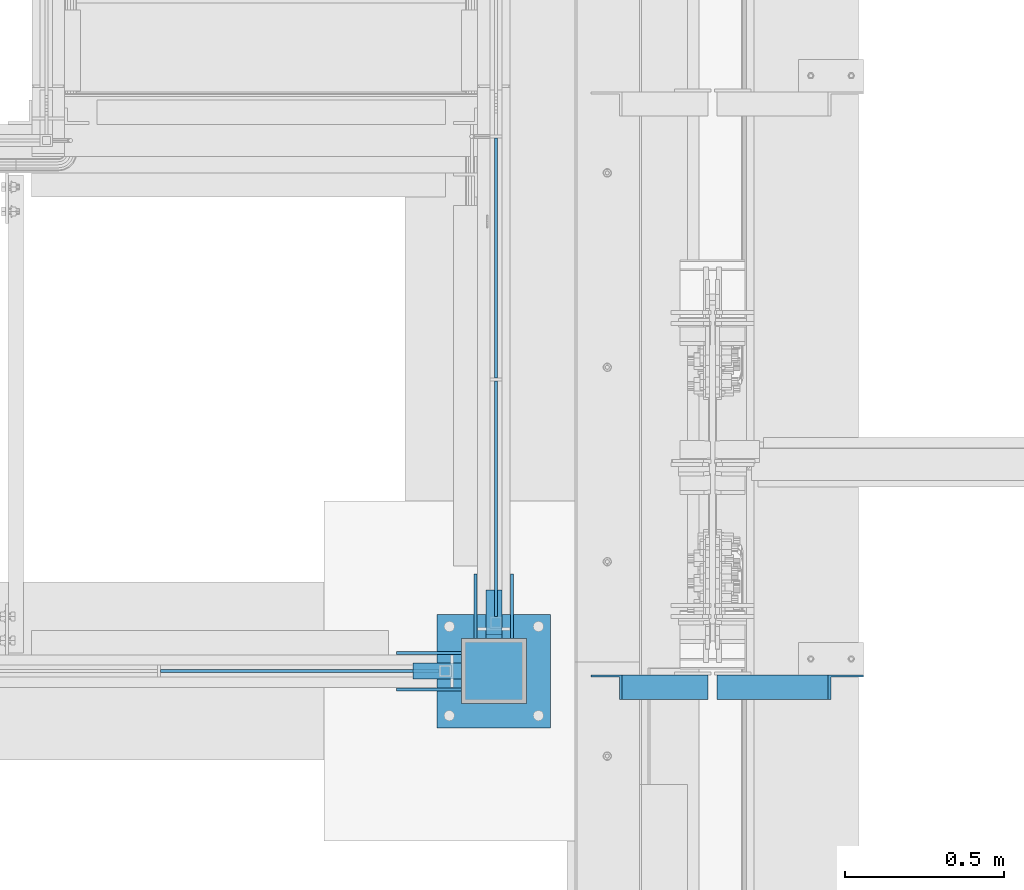
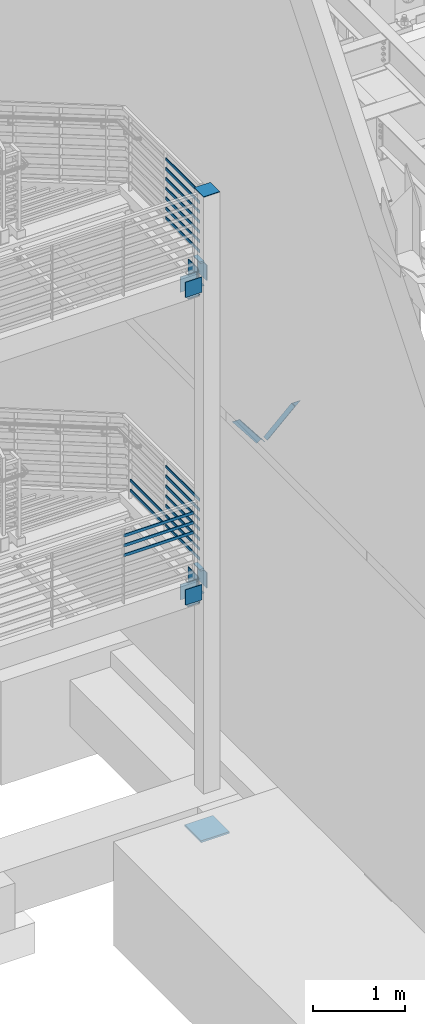
# One storey, part 833 of 1179: 35 beams, 2 members, 8 elements without a shape of their own.
"""IFC2X3 building model written with IfcOpenShell, lengths in millimetres."""

from ifc_helpers import new_model, si_unit, frame, origin_with_axes, place, context, subcontext, project, spatial, faceted_brep, material, type_object, element, aggregate, save


model = new_model("IFC2X3")

# Units and contexts
model_context = context("Model", 3, precision=1e-05, world=origin_with_axes())
body_context = subcontext(model_context, "Body", "Model", "MODEL_VIEW")
ifc_project = project(units=[si_unit("LENGTHUNIT", "METRE", prefix="MILLI"), si_unit("AREAUNIT", "SQUARE_METRE"), si_unit("VOLUMEUNIT", "CUBIC_METRE"), si_unit("MASSUNIT", "GRAM", prefix="KILO"), si_unit("TIMEUNIT", "SECOND"), si_unit("PLANEANGLEUNIT", "RADIAN"), si_unit("SOLIDANGLEUNIT", "STERADIAN"), si_unit("THERMODYNAMICTEMPERATUREUNIT", "DEGREE_CELSIUS"), si_unit("LUMINOUSINTENSITYUNIT", "LUMEN")], contexts=[model_context])

# Site, building, storey
site_placement = place(None, origin_with_axes())
site = spatial("IfcSite", under=ifc_project, at=site_placement, CompositionType="ELEMENT")
building_placement = place(site_placement, origin_with_axes())
building = spatial("IfcBuilding", under=site, at=building_placement, Name="Undefined", CompositionType="ELEMENT")
storey_placement = place(building_placement, origin_with_axes())
storey = spatial("IfcBuildingStorey", under=building, at=storey_placement, Name="Undefined", CompositionType="ELEMENT", Elevation=0.0)

# Assembly, beam
assembly_1_placement = place(storey_placement, origin_with_axes())
assembly_1 = element("IfcElementAssembly", 1, at=assembly_1_placement, inside=storey, Name="COLUMN", AssemblyPlace="NOTDEFINED", PredefinedType="RIGID_FRAME")
ifc_material_1 = material(Name="STEEL/A572-GR.50")
beam_type_1 = type_object("IfcBeamType", PredefinedType="NOTDEFINED")
beam_1_placement = place(assembly_1_placement, frame((-254.000000000004, 30327.6, 1857.375), z_axis=(1.0, 0.0, 0.0), x_axis=(0.0, -1.0, 0.0)))
beam_1 = element("IfcBeam", 2, at=beam_1_placement, type_object=beam_type_1, material=ifc_material_1, Name="PLATE", context=body_context, shape_type="Brep", body=[
    faceted_brep([(152.400000000001, -6.35000000000036, 25.4), (152.400000000001, -6.35000000000036, -25.4), (139.700000000004, 6.35000000000036, -25.4), (139.700000000004, 6.35000000000036, 25.4), (0.0, -6.35000000000036, -25.4000000000015), (0.0, -6.35000000000036, 25.4000000000015), (0.0, 6.35000000000036, 25.4000000000015), (0.0, 6.35000000000036, -25.4000000000015)], [[[0, 1, 2, 3]], [[4, 5, 6, 7]], [[6, 5, 0, 3]], [[7, 6, 3, 2]], [[4, 7, 2, 1]], [[5, 4, 1, 0]]]),
])

assembly_2_placement = place(storey_placement, origin_with_axes())
assembly_2 = element("IfcElementAssembly", 3, at=assembly_2_placement, inside=storey, Name="PLATE", AssemblyPlace="NOTDEFINED", PredefinedType="RIGID_FRAME")
beam_2_placement = place(assembly_2_placement, frame((-254.000000000004, 30327.6, 2174.875), z_axis=(1.0, 0.0, 0.0), x_axis=(0.0, -1.0, 0.0)))
beam_2 = element("IfcBeam", 4, at=beam_2_placement, type_object=beam_type_1, material=ifc_material_1, Name="PLATE", context=body_context, shape_type="Brep", body=[
    faceted_brep([(152.399999999998, 6.35000000000036, 25.4000000000015), (139.699999999998, -6.35000000000036, 25.4000000000015), (139.699999999998, -6.35000000000036, -25.4000000000015), (152.399999999998, 6.35000000000036, -25.4000000000015), (0.0, -6.35000000000036, -25.4000000000015), (0.0, -6.35000000000036, 25.4000000000015), (0.0, 6.35000000000036, 25.4000000000015), (0.0, 6.35000000000036, -25.4000000000015)], [[[0, 1, 2, 3]], [[4, 5, 6, 7]], [[7, 6, 0, 3]], [[4, 7, 3, 2]], [[5, 4, 2, 1]], [[6, 5, 1, 0]]]),
])
aggregate(assembly_2, [beam_2])

# Beam
beam_3_placement = place(assembly_1_placement, frame((-254.000000000004, 30327.6, 5930.9), z_axis=(1.0, 0.0, 0.0), x_axis=(0.0, -1.0, 0.0)))
beam_3 = element("IfcBeam", 5, at=beam_3_placement, type_object=beam_type_1, material=ifc_material_1, Name="PLATE", context=body_context, shape_type="Brep", body=[
    faceted_brep([(152.400000000001, -6.35000000000036, 25.4), (152.400000000001, -6.35000000000036, -25.4), (139.700000000004, 6.35000000000036, -25.4), (139.700000000004, 6.35000000000036, 25.4), (0.0, -6.35000000000036, -25.4000000000015), (0.0, -6.35000000000036, 25.4000000000015), (0.0, 6.35000000000036, 25.4000000000015), (0.0, 6.35000000000036, -25.4000000000015)], [[[0, 1, 2, 3]], [[4, 5, 6, 7]], [[6, 5, 0, 3]], [[7, 6, 3, 2]], [[4, 7, 2, 1]], [[5, 4, 1, 0]]]),
])

# Assembly, beam
assembly_3_placement = place(storey_placement, origin_with_axes())
assembly_3 = element("IfcElementAssembly", 6, at=assembly_3_placement, inside=storey, Name="PLATE", AssemblyPlace="NOTDEFINED", PredefinedType="RIGID_FRAME")
beam_4_placement = place(assembly_3_placement, frame((-254.000000000004, 30327.6, 6248.4), z_axis=(1.0, 0.0, 0.0), x_axis=(0.0, -1.0, 0.0)))
beam_4 = element("IfcBeam", 7, at=beam_4_placement, type_object=beam_type_1, material=ifc_material_1, Name="PLATE", context=body_context, shape_type="Brep", body=[
    faceted_brep([(152.399999999998, 6.35000000000036, 25.4000000000015), (139.699999999998, -6.35000000000036, 25.4000000000015), (139.699999999998, -6.35000000000036, -25.4000000000015), (152.399999999998, 6.35000000000036, -25.4000000000015), (0.0, -6.35000000000036, -25.4000000000015), (0.0, -6.35000000000036, 25.4000000000015), (0.0, 6.35000000000036, 25.4000000000015), (0.0, 6.35000000000036, -25.4000000000015)], [[[0, 1, 2, 3]], [[4, 5, 6, 7]], [[7, 6, 0, 3]], [[4, 7, 3, 2]], [[5, 4, 2, 1]], [[6, 5, 1, 0]]]),
])
aggregate(assembly_3, [beam_4])

# Beam
beam_5_placement = place(assembly_1_placement, frame((-508.0, 30073.6, 1857.375), z_axis=(0.0, 1.0, 0.0), x_axis=(1.0, 0.0, 0.0)))
beam_5 = element("IfcBeam", 8, at=beam_5_placement, type_object=beam_type_1, material=ifc_material_1, Name="PLATE", context=body_context, shape_type="Brep", body=[
    faceted_brep([(152.400000000001, -6.35000000000036, 25.4), (152.400000000001, -6.35000000000036, -25.4), (139.700000000004, 6.35000000000036, -25.4), (139.700000000004, 6.35000000000036, 25.4), (0.0, -6.35000000000036, -25.4000000000015), (0.0, -6.35000000000036, 25.4000000000015), (0.0, 6.35000000000036, 25.4000000000015), (0.0, 6.35000000000036, -25.4000000000015)], [[[0, 1, 2, 3]], [[4, 5, 6, 7]], [[6, 5, 0, 3]], [[7, 6, 3, 2]], [[4, 7, 2, 1]], [[5, 4, 1, 0]]]),
])

beam_6_placement = place(assembly_1_placement, frame((-508.0, 30073.6, 5930.9), z_axis=(0.0, 1.0, 0.0), x_axis=(1.0, 0.0, 0.0)))
beam_6 = element("IfcBeam", 9, at=beam_6_placement, type_object=beam_type_1, material=ifc_material_1, Name="PLATE", context=body_context, shape_type="Brep", body=[
    faceted_brep([(152.400000000001, -6.35000000000036, 25.4), (152.400000000001, -6.35000000000036, -25.4), (139.700000000004, 6.35000000000036, -25.4), (139.700000000004, 6.35000000000036, 25.4), (0.0, -6.35000000000036, -25.4000000000015), (0.0, -6.35000000000036, 25.4000000000015), (0.0, 6.35000000000036, 25.4000000000015), (0.0, 6.35000000000036, -25.4000000000015)], [[[0, 1, 2, 3]], [[4, 5, 6, 7]], [[6, 5, 0, 3]], [[7, 6, 3, 2]], [[4, 7, 2, 1]], [[5, 4, 1, 0]]]),
])

# Assembly, beams
assembly_4_placement = place(storey_placement, origin_with_axes())
assembly_4 = element("IfcElementAssembly", 10, at=assembly_4_placement, inside=storey, Name="GUARDRAIL", AssemblyPlace="NOTDEFINED", PredefinedType="RIGID_FRAME")
ifc_material_2 = material(Name="STEEL/A36")
beam_type_2 = type_object("IfcBeamType", PredefinedType="NOTDEFINED")
beam_7_placement = place(assembly_4_placement, frame((-247.650000725317, 31749.9983091745, 2276.5279178492), z_axis=(0.0, 0.0, 1.0), x_axis=(0.0, -1.0, 0.0)))
beam_7 = element("IfcBeam", 11, at=beam_7_placement, type_object=beam_type_2, material=ifc_material_2, Name="PLATE", context=body_context, shape_type="Brep", body=[
    faceted_brep([(4.76250000197615, 4.76249999999999, -19.0500000000002), (4.76250000197615, 4.76249999999999, 19.0500000000002), (757.237500001975, 4.76249999999999, 19.0500000000002), (757.237500001975, 4.76249999999999, -19.0500000000002), (4.76250000197615, -4.76249999999999, 19.0500000000002), (757.237500001975, -4.76249999999999, 19.0500000000002), (4.76250000197615, -4.76249999999999, -19.0500000000002), (757.237500001975, -4.76249999999999, -19.0500000000002)], [[[0, 1, 2, 3]], [[1, 4, 5, 2]], [[4, 6, 7, 5]], [[6, 0, 3, 7]], [[5, 7, 3, 2]], [[6, 4, 1, 0]]]),
])
beam_8_placement = place(assembly_4_placement, frame((-247.650000725386, 31749.9983091554, 2406.70291789415), z_axis=(0.0, 0.0, 1.0), x_axis=(0.0, -1.0, 0.0)))
beam_8 = element("IfcBeam", 12, at=beam_8_placement, type_object=beam_type_2, material=ifc_material_2, Name="PLATE", context=body_context, shape_type="Brep", body=[
    faceted_brep([(4.76250000197615, 4.76249999999999, -19.0500000000002), (4.76250000197615, 4.76249999999999, 19.0500000000002), (757.237500001975, 4.76249999999999, 19.0500000000002), (757.237500001975, 4.76249999999999, -19.0500000000002), (4.76250000197615, -4.76249999999999, 19.0500000000002), (757.237500001975, -4.76249999999999, 19.0500000000002), (4.76250000197615, -4.76249999999999, -19.0500000000002), (757.237500001975, -4.76249999999999, -19.0500000000002)], [[[0, 1, 2, 3]], [[1, 4, 5, 2]], [[4, 6, 7, 5]], [[6, 0, 3, 7]], [[5, 7, 3, 2]], [[6, 4, 1, 0]]]),
])

assembly_5_placement = place(storey_placement, origin_with_axes())
assembly_5 = element("IfcElementAssembly", 13, at=assembly_5_placement, inside=storey, Name="GUARDRAIL", AssemblyPlace="NOTDEFINED", PredefinedType="RIGID_FRAME")
beam_9_placement = place(assembly_5_placement, frame((-1303.86666666667, 30073.6, 2797.22791866566), z_axis=(0.0, 0.0, 1.0), x_axis=(1.0, 0.0, 0.0)))
beam_9 = element("IfcBeam", 14, at=beam_9_placement, type_object=beam_type_2, material=ifc_material_2, Name="PLATE", context=body_context, shape_type="Brep", body=[
    faceted_brep([(4.76250000197615, 4.76249999999999, -19.0500000000002), (4.76250000197615, 4.76249999999999, 19.0500000000002), (878.416667431667, 4.76249999999709, 19.0499999999993), (878.416667431667, 4.76249999999709, -19.0499999999993), (4.76250000197615, -4.76249999999999, 19.0500000000002), (878.416667431667, -4.76249999999709, 19.0499999999993), (4.76250000197615, -4.76249999999999, -19.0500000000002), (878.416667431667, -4.76249999999709, -19.0499999999993)], [[[0, 1, 2, 3]], [[1, 4, 5, 2]], [[4, 6, 7, 5]], [[6, 0, 3, 7]], [[5, 7, 3, 2]], [[6, 4, 1, 0]]]),
])
beam_10_placement = place(assembly_5_placement, frame((-1303.86666666667, 30073.6, 2927.40291866915), z_axis=(0.0, 0.0, 1.0), x_axis=(1.0, 0.0, 0.0)))
beam_10 = element("IfcBeam", 15, at=beam_10_placement, type_object=beam_type_2, material=ifc_material_2, Name="PLATE", context=body_context, shape_type="Brep", body=[
    faceted_brep([(4.76250000197615, 4.76249999999999, -19.0500000000002), (4.76250000197615, 4.76249999999999, 19.0500000000002), (878.416667431667, 4.76249999999709, 19.0499999999993), (878.416667431667, 4.76249999999709, -19.0499999999993), (4.76250000197615, -4.76249999999999, 19.0500000000002), (878.416667431667, -4.76249999999709, 19.0499999999993), (4.76250000197615, -4.76249999999999, -19.0500000000002), (878.416667431667, -4.76249999999709, -19.0499999999993)], [[[0, 1, 2, 3]], [[1, 4, 5, 2]], [[4, 6, 7, 5]], [[6, 0, 3, 7]], [[5, 7, 3, 2]], [[6, 4, 1, 0]]]),
])
beam_11_placement = place(assembly_5_placement, frame((-1303.86666666667, 30073.6, 3057.57791866915), z_axis=(0.0, 0.0, 1.0), x_axis=(1.0, 0.0, 0.0)))
beam_11 = element("IfcBeam", 16, at=beam_11_placement, type_object=beam_type_2, material=ifc_material_2, Name="PLATE", context=body_context, shape_type="Brep", body=[
    faceted_brep([(4.76250000197615, 4.76249999999999, -19.0500000000002), (4.76250000197615, 4.76249999999999, 19.0500000000002), (878.416667431667, 4.76249999999709, 19.0499999999993), (878.416667431667, 4.76249999999709, -19.0499999999993), (4.76250000197615, -4.76249999999999, 19.0500000000002), (878.416667431667, -4.76249999999709, 19.0499999999993), (4.76250000197615, -4.76249999999999, -19.0500000000002), (878.416667431667, -4.76249999999709, -19.0499999999993)], [[[0, 1, 2, 3]], [[1, 4, 5, 2]], [[4, 6, 7, 5]], [[6, 0, 3, 7]], [[5, 7, 3, 2]], [[6, 4, 1, 0]]]),
])
aggregate(assembly_5, [beam_9, beam_10, beam_11])

assembly_6_placement = place(storey_placement, origin_with_axes())
assembly_6 = element("IfcElementAssembly", 17, at=assembly_6_placement, inside=storey, Name="GUARDRAIL", AssemblyPlace="NOTDEFINED", PredefinedType="RIGID_FRAME")
beam_12_placement = place(assembly_6_placement, frame((-247.650000731256, 30987.9983091817, 6349.99999898763), z_axis=(0.0, 0.0, 1.0), x_axis=(0.0, -1.0, 0.0)))
beam_12 = element("IfcBeam", 18, at=beam_12_placement, type_object=beam_type_2, material=ifc_material_2, Name="PLATE", context=body_context, shape_type="Brep", body=[
    faceted_brep([(4.76250000197615, 4.76249999999999, -19.0500000000002), (4.76250000197615, 4.76249999999999, 19.0500000000002), (742.949804317075, 4.76249999999999, 19.0500000000002), (742.949869772874, 4.76249999999999, -19.0500000000002), (4.76250000197615, -4.76249999999999, 19.0500000000002), (742.949804317075, -4.76249999999999, 19.0500000000002), (4.76250000197615, -4.76249999999999, -19.0500000000002), (742.949869772874, -4.76249999999999, -19.0500000000002)], [[[0, 1, 2, 3]], [[1, 4, 5, 2]], [[4, 6, 7, 5]], [[6, 0, 3, 7]], [[5, 7, 3, 2]], [[6, 4, 1, 0]]]),
])
beam_13_placement = place(assembly_6_placement, frame((-247.650000731256, 30987.9983091455, 6480.17499943555), z_axis=(0.0, 0.0, 1.0), x_axis=(0.0, -1.0, 0.0)))
beam_13 = element("IfcBeam", 19, at=beam_13_placement, type_object=beam_type_2, material=ifc_material_2, Name="PLATE", context=body_context, shape_type="Brep", body=[
    faceted_brep([(4.76250000197615, 4.76249999999999, -19.0500000000002), (4.76250000197615, 4.76249999999999, 19.0500000000002), (742.949580659377, 4.76249999999999, 19.0500000003303), (742.949646077075, 4.76249999999999, -19.0499999996691), (4.76250000197615, -4.76249999999999, 19.0500000000002), (742.949580659377, -4.76249999999999, 19.0500000003303), (4.76250000197615, -4.76249999999999, -19.0500000000002), (742.949646077075, -4.76249999999999, -19.0499999996691)], [[[0, 1, 2, 3]], [[1, 4, 5, 2]], [[4, 6, 7, 5]], [[6, 0, 3, 7]], [[5, 7, 3, 2]], [[6, 4, 1, 0]]]),
])
beam_14_placement = place(assembly_6_placement, frame((-247.650000731256, 30987.9983091848, 6610.34999899487), z_axis=(0.0, 0.0, 1.0), x_axis=(0.0, -1.0, 0.0)))
beam_14 = element("IfcBeam", 20, at=beam_14_placement, type_object=beam_type_2, material=ifc_material_2, Name="PLATE", context=body_context, shape_type="Brep", body=[
    faceted_brep([(4.76250000197615, 4.76249999999999, -19.0500000000002), (4.76250000197615, 4.76249999999999, 19.0500000000002), (742.949357039182, 4.76249999999999, 19.0500000000002), (742.949422494981, 4.76249999999999, -19.0500000000002), (4.76250000197615, -4.76249999999999, 19.0500000000002), (742.949357039182, -4.76249999999999, 19.0500000000002), (4.76250000197615, -4.76249999999999, -19.0500000000002), (742.949422494981, -4.76249999999999, -19.0500000000002)], [[[0, 1, 2, 3]], [[1, 4, 5, 2]], [[4, 6, 7, 5]], [[6, 0, 3, 7]], [[5, 7, 3, 2]], [[6, 4, 1, 0]]]),
])
beam_15_placement = place(assembly_6_placement, frame((-247.650000731256, 30987.9983091848, 6740.525000008), z_axis=(0.0, 0.0, 1.0), x_axis=(0.0, -1.0, 0.0)))
beam_15 = element("IfcBeam", 21, at=beam_15_placement, type_object=beam_type_2, material=ifc_material_2, Name="PLATE", context=body_context, shape_type="Brep", body=[
    faceted_brep([(4.76250000197615, 4.76249999999999, -19.0500000000002), (4.76250000197615, 4.76249999999999, 19.0500000000002), (742.949133398644, 4.76249999999999, 19.0500000000002), (742.949198854443, 4.76249999999999, -19.0500000000002), (4.76250000197615, -4.76249999999999, 19.0500000000002), (742.949133398644, -4.76249999999999, 19.0500000000002), (4.76250000197615, -4.76249999999999, -19.0500000000002), (742.949198854443, -4.76249999999999, -19.0500000000002)], [[[0, 1, 2, 3]], [[1, 4, 5, 2]], [[4, 6, 7, 5]], [[6, 0, 3, 7]], [[5, 7, 3, 2]], [[6, 4, 1, 0]]]),
])
beam_16_placement = place(assembly_6_placement, frame((-247.650000731256, 30987.9983091848, 6870.70000000627), z_axis=(0.0, 0.0, 1.0), x_axis=(0.0, -1.0, 0.0)))
beam_16 = element("IfcBeam", 22, at=beam_16_placement, type_object=beam_type_2, material=ifc_material_2, Name="PLATE", context=body_context, shape_type="Brep", body=[
    faceted_brep([(4.76250000197615, 4.76249999999999, -19.0500000000002), (4.76250000197615, 4.76249999999999, 19.0500000000002), (742.948909758103, 4.76249999999999, 19.0500000000002), (742.948975213902, 4.76249999999999, -19.0500000000002), (4.76250000197615, -4.76249999999999, 19.0500000000002), (742.948909758103, -4.76249999999999, 19.0500000000002), (4.76250000197615, -4.76249999999999, -19.0500000000002), (742.948975213902, -4.76249999999999, -19.0500000000002)], [[[0, 1, 2, 3]], [[1, 4, 5, 2]], [[4, 6, 7, 5]], [[6, 0, 3, 7]], [[5, 7, 3, 2]], [[6, 4, 1, 0]]]),
])
beam_17_placement = place(assembly_6_placement, frame((-247.650000731256, 30987.9983091848, 7000.87500000976), z_axis=(0.0, 0.0, 1.0), x_axis=(0.0, -1.0, 0.0)))
beam_17 = element("IfcBeam", 23, at=beam_17_placement, type_object=beam_type_2, material=ifc_material_2, Name="PLATE", context=body_context, shape_type="Brep", body=[
    faceted_brep([(4.76250000197615, 4.76249999999999, -19.0500000000002), (4.76250000197615, 4.76249999999999, 19.0500000000002), (742.948686117568, 4.76249999999999, 19.0500000000002), (742.948751573367, 4.76249999999999, -19.0500000000002), (4.76250000197615, -4.76249999999999, 19.0500000000002), (742.948686117568, -4.76249999999999, 19.0500000000002), (4.76250000197615, -4.76249999999999, -19.0500000000002), (742.948751573367, -4.76249999999999, -19.0500000000002)], [[[0, 1, 2, 3]], [[1, 4, 5, 2]], [[4, 6, 7, 5]], [[6, 0, 3, 7]], [[5, 7, 3, 2]], [[6, 4, 1, 0]]]),
])
beam_18_placement = place(assembly_6_placement, frame((-247.650000731256, 30987.9983091848, 7131.050000015), z_axis=(0.0, 0.0, 1.0), x_axis=(0.0, -1.0, 0.0)))
beam_18 = element("IfcBeam", 24, at=beam_18_placement, type_object=beam_type_2, material=ifc_material_2, Name="PLATE", context=body_context, shape_type="Brep", body=[
    faceted_brep([(4.76250000197615, 4.76249999999999, -19.0500000000002), (4.76250000197615, 4.76249999999999, 19.0500000000002), (742.948462477041, 4.76249999999999, 19.0500000000002), (742.94852793284, 4.76249999999999, -19.0500000000002), (4.76250000197615, -4.76249999999999, 19.0500000000002), (742.948462477041, -4.76249999999999, 19.0500000000002), (4.76250000197615, -4.76249999999999, -19.0500000000002), (742.94852793284, -4.76249999999999, -19.0500000000002)], [[[0, 1, 2, 3]], [[1, 4, 5, 2]], [[4, 6, 7, 5]], [[6, 0, 3, 7]], [[5, 7, 3, 2]], [[6, 4, 1, 0]]]),
])
aggregate(assembly_6, [beam_12, beam_13, beam_14, beam_15, beam_16, beam_17, beam_18])

# Beam
beam_19_placement = place(assembly_4_placement, frame((-247.650000731058, 30987.9983091725, 2276.5279178486), z_axis=(0.0, 0.0, 1.0), x_axis=(0.0, -1.0, 0.0)))
beam_19 = element("IfcBeam", 25, at=beam_19_placement, type_object=beam_type_2, material=ifc_material_2, Name="PLATE", context=body_context, shape_type="Brep", body=[
    faceted_brep([(4.76250000197615, 4.76249999999999, -19.0500000000002), (4.76250000197615, 4.76249999999999, 19.0500000000002), (742.949804317075, 4.76249999999999, 19.0500000000002), (742.949869772874, 4.76249999999999, -19.0500000000002), (4.76250000197615, -4.76249999999999, 19.0500000000002), (742.949804317075, -4.76249999999999, 19.0500000000002), (4.76250000197615, -4.76249999999999, -19.0500000000002), (742.949869772874, -4.76249999999999, -19.0500000000002)], [[[0, 1, 2, 3]], [[1, 4, 5, 2]], [[4, 6, 7, 5]], [[6, 0, 3, 7]], [[5, 7, 3, 2]], [[6, 4, 1, 0]]]),
])

beam_20_placement = place(assembly_4_placement, frame((-247.650000731058, 30987.9983091363, 2406.70291829651), z_axis=(0.0, 0.0, 1.0), x_axis=(0.0, -1.0, 0.0)))
beam_20 = element("IfcBeam", 26, at=beam_20_placement, type_object=beam_type_2, material=ifc_material_2, Name="PLATE", context=body_context, shape_type="Brep", body=[
    faceted_brep([(4.76250000197615, 4.76249999999999, -19.0500000000002), (4.76250000197615, 4.76249999999999, 19.0500000000002), (742.949580659377, 4.76249999999999, 19.0500000003303), (742.949646077075, 4.76249999999999, -19.0499999996691), (4.76250000197615, -4.76249999999999, 19.0500000000002), (742.949580659377, -4.76249999999999, 19.0500000003303), (4.76250000197615, -4.76249999999999, -19.0500000000002), (742.949646077075, -4.76249999999999, -19.0499999996691)], [[[0, 1, 2, 3]], [[1, 4, 5, 2]], [[4, 6, 7, 5]], [[6, 0, 3, 7]], [[5, 7, 3, 2]], [[6, 4, 1, 0]]]),
])

beam_21_placement = place(assembly_4_placement, frame((-247.650000731058, 30987.9983091725, 2536.87791785583), z_axis=(0.0, 0.0, 1.0), x_axis=(0.0, -1.0, 0.0)))
beam_21 = element("IfcBeam", 27, at=beam_21_placement, type_object=beam_type_2, material=ifc_material_2, Name="PLATE", context=body_context, shape_type="Brep", body=[
    faceted_brep([(4.76250000197615, 4.76249999999999, -19.0500000000002), (4.76250000197615, 4.76249999999999, 19.0500000000002), (742.949357039182, 4.76249999999999, 19.0500000000002), (742.949422494981, 4.76249999999999, -19.0500000000002), (4.76250000197615, -4.76249999999999, 19.0500000000002), (742.949357039182, -4.76249999999999, 19.0500000000002), (4.76250000197615, -4.76249999999999, -19.0500000000002), (742.949422494981, -4.76249999999999, -19.0500000000002)], [[[0, 1, 2, 3]], [[1, 4, 5, 2]], [[4, 6, 7, 5]], [[6, 0, 3, 7]], [[5, 7, 3, 2]], [[6, 4, 1, 0]]]),
])

beam_22_placement = place(assembly_4_placement, frame((-247.650000731058, 30987.9983091725, 2667.05291886897), z_axis=(0.0, 0.0, 1.0), x_axis=(0.0, -1.0, 0.0)))
beam_22 = element("IfcBeam", 28, at=beam_22_placement, type_object=beam_type_2, material=ifc_material_2, Name="PLATE", context=body_context, shape_type="Brep", body=[
    faceted_brep([(4.76250000197615, 4.76249999999999, -19.0500000000002), (4.76250000197615, 4.76249999999999, 19.0500000000002), (742.949133398644, 4.76249999999999, 19.0500000000002), (742.949198854443, 4.76249999999999, -19.0500000000002), (4.76250000197615, -4.76249999999999, 19.0500000000002), (742.949133398644, -4.76249999999999, 19.0500000000002), (4.76250000197615, -4.76249999999999, -19.0500000000002), (742.949198854443, -4.76249999999999, -19.0500000000002)], [[[0, 1, 2, 3]], [[1, 4, 5, 2]], [[4, 6, 7, 5]], [[6, 0, 3, 7]], [[5, 7, 3, 2]], [[6, 4, 1, 0]]]),
])

beam_23_placement = place(assembly_4_placement, frame((-247.650000731058, 30987.9983091725, 2797.22791886724), z_axis=(0.0, 0.0, 1.0), x_axis=(0.0, -1.0, 0.0)))
beam_23 = element("IfcBeam", 29, at=beam_23_placement, type_object=beam_type_2, material=ifc_material_2, Name="PLATE", context=body_context, shape_type="Brep", body=[
    faceted_brep([(4.76250000197615, 4.76249999999999, -19.0500000000002), (4.76250000197615, 4.76249999999999, 19.0500000000002), (742.948909758103, 4.76249999999999, 19.0500000000002), (742.948975213902, 4.76249999999999, -19.0500000000002), (4.76250000197615, -4.76249999999999, 19.0500000000002), (742.948909758103, -4.76249999999999, 19.0500000000002), (4.76250000197615, -4.76249999999999, -19.0500000000002), (742.948975213902, -4.76249999999999, -19.0500000000002)], [[[0, 1, 2, 3]], [[1, 4, 5, 2]], [[4, 6, 7, 5]], [[6, 0, 3, 7]], [[5, 7, 3, 2]], [[6, 4, 1, 0]]]),
])

beam_24_placement = place(assembly_4_placement, frame((-247.650000731058, 30987.9983091725, 2927.40291887072), z_axis=(0.0, 0.0, 1.0), x_axis=(0.0, -1.0, 0.0)))
beam_24 = element("IfcBeam", 30, at=beam_24_placement, type_object=beam_type_2, material=ifc_material_2, Name="PLATE", context=body_context, shape_type="Brep", body=[
    faceted_brep([(4.76250000197615, 4.76249999999999, -19.0500000000002), (4.76250000197615, 4.76249999999999, 19.0500000000002), (742.948686117568, 4.76249999999999, 19.0500000000002), (742.948751573367, 4.76249999999999, -19.0500000000002), (4.76250000197615, -4.76249999999999, 19.0500000000002), (742.948686117568, -4.76249999999999, 19.0500000000002), (4.76250000197615, -4.76249999999999, -19.0500000000002), (742.948751573367, -4.76249999999999, -19.0500000000002)], [[[0, 1, 2, 3]], [[1, 4, 5, 2]], [[4, 6, 7, 5]], [[6, 0, 3, 7]], [[5, 7, 3, 2]], [[6, 4, 1, 0]]]),
])

beam_25_placement = place(assembly_4_placement, frame((-247.650000731058, 30987.9983091725, 3057.57791887596), z_axis=(0.0, 0.0, 1.0), x_axis=(0.0, -1.0, 0.0)))
beam_25 = element("IfcBeam", 31, at=beam_25_placement, type_object=beam_type_2, material=ifc_material_2, Name="PLATE", context=body_context, shape_type="Brep", body=[
    faceted_brep([(4.76250000197615, 4.76249999999999, -19.0500000000002), (4.76250000197615, 4.76249999999999, 19.0500000000002), (742.948462477041, 4.76249999999999, 19.0500000000002), (742.94852793284, 4.76249999999999, -19.0500000000002), (4.76250000197615, -4.76249999999999, 19.0500000000002), (742.948462477041, -4.76249999999999, 19.0500000000002), (4.76250000197615, -4.76249999999999, -19.0500000000002), (742.94852793284, -4.76249999999999, -19.0500000000002)], [[[0, 1, 2, 3]], [[1, 4, 5, 2]], [[4, 6, 7, 5]], [[6, 0, 3, 7]], [[5, 7, 3, 2]], [[6, 4, 1, 0]]]),
])

aggregate(assembly_4, [beam_7, beam_8, beam_19, beam_20, beam_21, beam_22, beam_23, beam_24, beam_25])

# Assembly, member
assembly_7_placement = place(storey_placement, origin_with_axes())
assembly_7 = element("IfcElementAssembly", 32, at=assembly_7_placement, inside=storey, Name="ANGLE", AssemblyPlace="NOTDEFINED", PredefinedType="RIGID_FRAME")
member_type = type_object("IfcMemberType", Name="L3X3X1/4", PredefinedType="NOTDEFINED")
member_1_placement = place(assembly_7_placement, frame((472.414639168566, 30022.8, 3736.19330123132), z_axis=(0.0, -1.0, 0.0), x_axis=(0.729484494811633, 0.0, 0.683997347823379)))
member_1 = element("IfcMember", 33, at=member_1_placement, type_object=member_type, material=ifc_material_2, Name="ANGLE", ObjectType="L3X3X1/4", context=body_context, shape_type="Brep", body=[
    faceted_brep([(0.0, 38.0999999999985, -38.0999999999999), (0.0, 38.0999999999985, 38.0999999999999), (475.752341075195, 38.0999999999181, 38.1000000000004), (475.752341075195, 38.0999999999181, -38.1000000000004), (0.0, 31.75, 38.1000000000004), (482.524628360803, 31.7499999999177, 38.1000000000004), (0.0, 31.75, -31.75), (482.524628360803, 31.7499999999177, -31.75), (0.0, -38.0999999999985, -31.75), (557.019788502486, -38.1000000000854, -31.75), (0.0, -38.0999999999985, -38.0999999999999), (557.019788502486, -38.1000000000854, -38.1000000000004)], [[[0, 1, 2, 3]], [[1, 4, 5, 2]], [[4, 6, 7, 5]], [[6, 8, 9, 7]], [[8, 10, 11, 9]], [[10, 0, 3, 11]], [[5, 7, 9, 11, 3, 2]], [[10, 8, 6, 4, 1, 0]]]),
])
aggregate(assembly_7, [member_1])

assembly_8_placement = place(storey_placement, origin_with_axes())
assembly_8 = element("IfcElementAssembly", 34, at=assembly_8_placement, inside=storey, Name="ANGLE", AssemblyPlace="NOTDEFINED", PredefinedType="RIGID_FRAME")
member_2_placement = place(assembly_8_placement, frame((80.8196258456501, 30022.8, 4125.56128839178), z_axis=(0.0, -1.0, 0.0), x_axis=(0.614083067285056, 0.0, -0.789241399366364)))
member_2 = element("IfcMember", 35, at=member_2_placement, type_object=member_type, material=ifc_material_2, Name="ANGLE", ObjectType="L3X3X1/4", context=body_context, shape_type="Brep", body=[
    faceted_brep([(59.3707492954454, 38.0999999999781, -38.1000000000004), (59.3707492954454, 38.0999999999781, 38.1000000000004), (499.083854779058, 38.0999999998585, 38.1000000000004), (499.083854779058, 38.0999999998585, -38.1000000000004), (54.4300207928691, 31.7499999999804, 38.1000000000004), (499.083854779056, 31.7499999998595, 38.1000000000004), (54.4300207928691, 31.7499999999804, -31.75), (499.083854779056, 31.7499999998595, -31.75), (0.0820072645328764, -38.0999999999945, -31.75), (499.083854779043, -38.10000000013, -31.75), (0.0820072645328764, -38.0999999999945, -38.1000000000004), (499.083854779043, -38.10000000013, -38.1000000000004)], [[[0, 1, 2, 3]], [[1, 4, 5, 2]], [[4, 6, 7, 5]], [[6, 8, 9, 7]], [[8, 10, 11, 9]], [[10, 0, 3, 11]], [[5, 7, 9, 11, 3, 2]], [[10, 8, 6, 4, 1, 0]]]),
])
aggregate(assembly_8, [member_2])

# Beam
beam_type_3 = type_object("IfcBeamType", PredefinedType="NOTDEFINED")
beam_26_placement = place(assembly_1_placement, frame((-254.0, 29972.0, 7272.3375), z_axis=(1.0, 0.0, 0.0), x_axis=(0.0, 1.0, 0.0)))
beam_26 = element("IfcBeam", 36, at=beam_26_placement, type_object=beam_type_3, material=ifc_material_2, Name="PLATE", context=body_context, shape_type="Brep", body=[
    faceted_brep([(0.0, 4.76250000000073, -101.6), (0.0, 4.76250000000073, 101.6), (203.199999999997, 4.76250000000073, 101.6), (203.199999999997, 4.76250000000073, -101.6), (0.0, -4.76250000000073, 101.6), (203.199999999997, -4.76250000000073, 101.6), (0.0, -4.76250000000073, -101.6), (203.199999999997, -4.76250000000073, -101.6)], [[[0, 1, 2, 3]], [[1, 4, 5, 2]], [[4, 6, 7, 5]], [[6, 0, 3, 7]], [[5, 7, 3, 2]], [[6, 4, 1, 0]]]),
])

beam_27_placement = place(assembly_1_placement, frame((-311.150000014177, 30378.3999990897, 2016.07208180267), z_axis=(0.0, 0.0, 1.0), x_axis=(0.0, -1.0, 0.0)))
beam_27 = element("IfcBeam", 37, at=beam_27_placement, type_object=beam_type_3, material=ifc_material_2, Name="PLATE", context=body_context, shape_type="Brep", body=[
    faceted_brep([(0.0, 4.76250000000073, -101.6), (0.0, 4.76250000000073, 101.6), (203.199999999997, 4.76250000000073, 101.6), (203.199999999997, 4.76250000000073, -101.6), (0.0, -4.76250000000073, 101.6), (203.199999999997, -4.76250000000073, 101.6), (0.0, -4.76250000000073, -101.6), (203.199999999997, -4.76250000000073, -101.6)], [[[0, 1, 2, 3]], [[1, 4, 5, 2]], [[4, 6, 7, 5]], [[6, 0, 3, 7]], [[5, 7, 3, 2]], [[6, 4, 1, 0]]]),
])

beam_28_placement = place(assembly_1_placement, frame((-196.849999999999, 30378.4, 2016.125), z_axis=(0.0, 0.0, 1.0), x_axis=(0.0, -1.0, 0.0)))
beam_28 = element("IfcBeam", 38, at=beam_28_placement, type_object=beam_type_3, material=ifc_material_2, Name="PLATE", context=body_context, shape_type="Brep", body=[
    faceted_brep([(0.0, 4.76250000000073, -101.6), (0.0, 4.76250000000073, 101.6), (203.199999999997, 4.76250000000073, 101.6), (203.199999999997, 4.76250000000073, -101.6), (0.0, -4.76250000000073, 101.6), (203.199999999997, -4.76250000000073, 101.6), (0.0, -4.76250000000073, -101.6), (203.199999999997, -4.76250000000073, -101.6)], [[[0, 1, 2, 3]], [[1, 4, 5, 2]], [[4, 6, 7, 5]], [[6, 0, 3, 7]], [[5, 7, 3, 2]], [[6, 4, 1, 0]]]),
])

beam_29_placement = place(assembly_1_placement, frame((-196.849999999999, 30378.4, 6089.65), z_axis=(0.0, 0.0, 1.0), x_axis=(0.0, -1.0, 0.0)))
beam_29 = element("IfcBeam", 39, at=beam_29_placement, type_object=beam_type_3, material=ifc_material_2, Name="PLATE", context=body_context, shape_type="Brep", body=[
    faceted_brep([(0.0, 4.76250000000073, -101.6), (0.0, 4.76250000000073, 101.6), (203.199999999997, 4.76250000000073, 101.6), (203.199999999997, 4.76250000000073, -101.6), (0.0, -4.76250000000073, 101.6), (203.199999999997, -4.76250000000073, 101.6), (0.0, -4.76250000000073, -101.6), (203.199999999997, -4.76250000000073, -101.6)], [[[0, 1, 2, 3]], [[1, 4, 5, 2]], [[4, 6, 7, 5]], [[6, 0, 3, 7]], [[5, 7, 3, 2]], [[6, 4, 1, 0]]]),
])

beam_30_placement = place(assembly_1_placement, frame((-311.150000000001, 30378.4, 6089.65), z_axis=(0.0, 0.0, 1.0), x_axis=(0.0, -1.0, 0.0)))
beam_30 = element("IfcBeam", 40, at=beam_30_placement, type_object=beam_type_3, material=ifc_material_2, Name="PLATE", context=body_context, shape_type="Brep", body=[
    faceted_brep([(0.0, 4.76250000000073, -101.6), (0.0, 4.76250000000073, 101.6), (203.199999999997, 4.76250000000073, 101.6), (203.199999999997, 4.76250000000073, -101.6), (0.0, -4.76250000000073, 101.6), (203.199999999997, -4.76250000000073, 101.6), (0.0, -4.76250000000073, -101.6), (203.199999999997, -4.76250000000073, -101.6)], [[[0, 1, 2, 3]], [[1, 4, 5, 2]], [[4, 6, 7, 5]], [[6, 0, 3, 7]], [[5, 7, 3, 2]], [[6, 4, 1, 0]]]),
])

beam_31_placement = place(assembly_1_placement, frame((-558.8, 30130.75, 2016.125), z_axis=(0.0, 0.0, 1.0), x_axis=(1.0, 0.0, 0.0)))
beam_31 = element("IfcBeam", 41, at=beam_31_placement, type_object=beam_type_3, material=ifc_material_2, Name="PLATE", context=body_context, shape_type="Brep", body=[
    faceted_brep([(0.0, 4.76250000000073, -101.6), (0.0, 4.76250000000073, 101.6), (203.199999999997, 4.76250000000073, 101.6), (203.199999999997, 4.76250000000073, -101.6), (0.0, -4.76250000000073, 101.6), (203.199999999997, -4.76250000000073, 101.6), (0.0, -4.76250000000073, -101.6), (203.199999999997, -4.76250000000073, -101.6)], [[[0, 1, 2, 3]], [[1, 4, 5, 2]], [[4, 6, 7, 5]], [[6, 0, 3, 7]], [[5, 7, 3, 2]], [[6, 4, 1, 0]]]),
])

beam_32_placement = place(assembly_1_placement, frame((-558.8, 30016.45, 2016.125), z_axis=(0.0, 0.0, 1.0), x_axis=(1.0, 0.0, 0.0)))
beam_32 = element("IfcBeam", 42, at=beam_32_placement, type_object=beam_type_3, material=ifc_material_2, Name="PLATE", context=body_context, shape_type="Brep", body=[
    faceted_brep([(0.0, 4.76250000000073, -101.6), (0.0, 4.76250000000073, 101.6), (203.199999999997, 4.76250000000073, 101.6), (203.199999999997, 4.76250000000073, -101.6), (0.0, -4.76250000000073, 101.6), (203.199999999997, -4.76250000000073, 101.6), (0.0, -4.76250000000073, -101.6), (203.199999999997, -4.76250000000073, -101.6)], [[[0, 1, 2, 3]], [[1, 4, 5, 2]], [[4, 6, 7, 5]], [[6, 0, 3, 7]], [[5, 7, 3, 2]], [[6, 4, 1, 0]]]),
])

beam_33_placement = place(assembly_1_placement, frame((-558.8, 30130.75, 6089.65), z_axis=(0.0, 0.0, 1.0), x_axis=(1.0, 0.0, 0.0)))
beam_33 = element("IfcBeam", 43, at=beam_33_placement, type_object=beam_type_3, material=ifc_material_2, Name="PLATE", context=body_context, shape_type="Brep", body=[
    faceted_brep([(0.0, 4.76250000000073, -101.6), (0.0, 4.76250000000073, 101.6), (203.199999999997, 4.76250000000073, 101.6), (203.199999999997, 4.76250000000073, -101.6), (0.0, -4.76250000000073, 101.6), (203.199999999997, -4.76250000000073, 101.6), (0.0, -4.76250000000073, -101.6), (203.199999999997, -4.76250000000073, -101.6)], [[[0, 1, 2, 3]], [[1, 4, 5, 2]], [[4, 6, 7, 5]], [[6, 0, 3, 7]], [[5, 7, 3, 2]], [[6, 4, 1, 0]]]),
])

beam_34_placement = place(assembly_1_placement, frame((-558.8, 30016.45, 6089.65), z_axis=(0.0, 0.0, 1.0), x_axis=(1.0, 0.0, 0.0)))
beam_34 = element("IfcBeam", 44, at=beam_34_placement, type_object=beam_type_3, material=ifc_material_2, Name="PLATE", context=body_context, shape_type="Brep", body=[
    faceted_brep([(0.0, 4.76250000000073, -101.6), (0.0, 4.76250000000073, 101.6), (203.199999999997, 4.76250000000073, 101.6), (203.199999999997, 4.76250000000073, -101.6), (0.0, -4.76250000000073, 101.6), (203.199999999997, -4.76250000000073, 101.6), (0.0, -4.76250000000073, -101.6), (203.199999999997, -4.76250000000073, -101.6)], [[[0, 1, 2, 3]], [[1, 4, 5, 2]], [[4, 6, 7, 5]], [[6, 0, 3, 7]], [[5, 7, 3, 2]], [[6, 4, 1, 0]]]),
])

beam_type_4 = type_object("IfcBeamType", PredefinedType="NOTDEFINED")
beam_35_placement = place(assembly_1_placement, frame((-254.0, 29895.8000030518, -1193.8), z_axis=(-1.0, 0.0, 0.0), x_axis=(0.0, 1.0, 0.0)))
beam_35 = element("IfcBeam", 45, at=beam_35_placement, type_object=beam_type_4, material=ifc_material_1, context=body_context, shape_type="Brep", body=[
    faceted_brep([(0.0, 12.7, -177.8), (9.50323374127038e-06, 12.7000000000007, 177.80000656152), (355.599999999999, 12.7, 177.8), (355.599999999999, 12.7, -177.8), (9.50323374127038e-06, -12.7000000000007, 177.80000656152), (355.599999999999, -12.7, 177.8), (0.0, -12.7, -177.8), (355.599999999999, -12.7, -177.8)], [[[0, 1, 2, 3]], [[1, 4, 5, 2]], [[4, 6, 7, 5]], [[6, 0, 3, 7]], [[5, 7, 3, 2]], [[6, 4, 1, 0]]]),
])

aggregate(assembly_1, [beam_26, beam_27, beam_28, beam_29, beam_30, beam_1, beam_3, beam_31, beam_32, beam_5, beam_33, beam_34, beam_6, beam_35])

save(model, "model.ifc")
